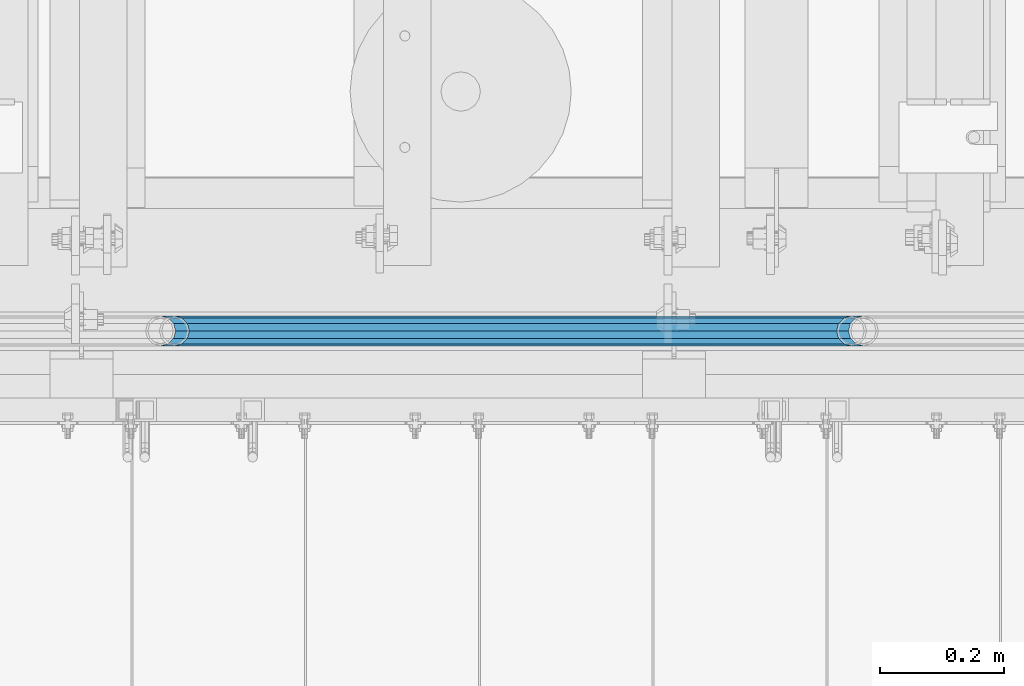
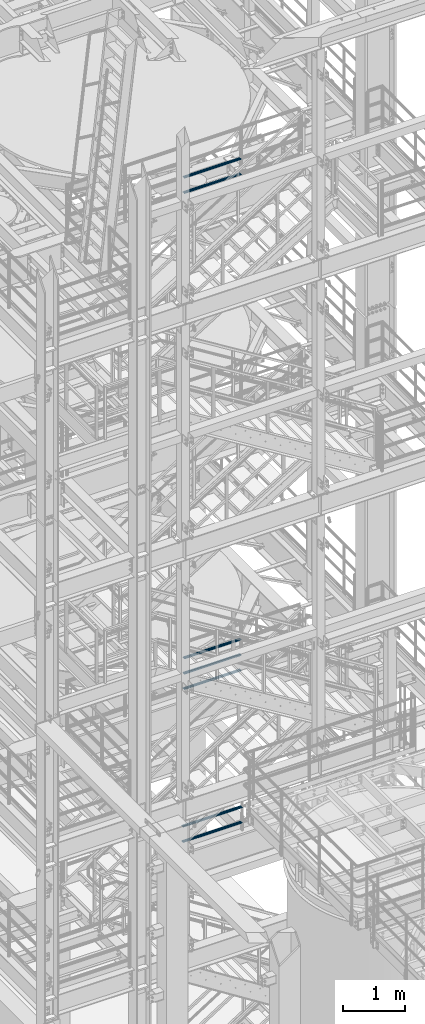
# One storey, part 977 of 1876: 7 beams, 3 elements without a shape of their own.
"""IFC2X3 building model written with IfcOpenShell, lengths in millimetres."""

from ifc_helpers import new_model, si_unit, frame, origin_with_axes, place, context, subcontext, project, spatial, faceted_brep, material, type_object, element, aggregate, save


model = new_model("IFC2X3")

# Units and contexts
model_context = context("Model", 3, precision=1e-05, world=origin_with_axes())
body_context = subcontext(model_context, "Body", "Model", "MODEL_VIEW")
ifc_project = project(units=[si_unit("LENGTHUNIT", "METRE", prefix="MILLI"), si_unit("AREAUNIT", "SQUARE_METRE"), si_unit("VOLUMEUNIT", "CUBIC_METRE"), si_unit("MASSUNIT", "GRAM", prefix="KILO"), si_unit("TIMEUNIT", "SECOND"), si_unit("PLANEANGLEUNIT", "RADIAN"), si_unit("SOLIDANGLEUNIT", "STERADIAN"), si_unit("THERMODYNAMICTEMPERATUREUNIT", "DEGREE_CELSIUS"), si_unit("LUMINOUSINTENSITYUNIT", "LUMEN")], contexts=[model_context])

# Site, building, storey
site_placement = place(None, origin_with_axes())
site = spatial("IfcSite", under=ifc_project, at=site_placement, CompositionType="ELEMENT")
building_placement = place(site_placement, origin_with_axes())
building = spatial("IfcBuilding", under=site, at=building_placement, Name="Undefined", CompositionType="ELEMENT")
storey_placement = place(building_placement, origin_with_axes())
storey = spatial("IfcBuildingStorey", under=building, at=storey_placement, Name="Undefined", CompositionType="ELEMENT", Elevation=0.0)

# Assembly, beams
assembly_1_placement = place(storey_placement, origin_with_axes())
assembly_1 = element("IfcElementAssembly", 1, at=assembly_1_placement, inside=storey, Name="RAIL", AssemblyPlace="NOTDEFINED", PredefinedType="RIGID_FRAME")
ifc_material = material()
beam_type = type_object("IfcBeamType", Name="PIPE1-1/2SCH40", PredefinedType="NOTDEFINED")
beam_1_placement = place(assembly_1_placement, frame((3937.00000015569, -4654.55000114549, 5292.725), z_axis=(0.0, 0.0, 1.0), x_axis=(1.0, 0.0, 0.0)))
beam_1 = element("IfcBeam", 2, at=beam_1_placement, type_object=beam_type, material=ifc_material, Name="RAIL", ObjectType="PIPE1-1/2SCH40", context=body_context, shape_type="Brep", body=[
    faceted_brep([(1109.40280692884, -12.0649999999996, 20.8971929933186), (1109.40280692884, -12.0650000000269, 15.8661214311533), (1108.90937849097, -10.2235000000001, 17.7076214311801), (1106.16999992216, -9.09494701772928e-13, 20.4470000000001), (1106.16999992216, -9.09494701772928e-13, 24.1300000000001), (1108.90937849099, 10.2235000000001, 17.7076214311801), (1109.40280692884, 12.0649999999723, 15.8661214312078), (1109.40280692884, 12.0649999999996, 20.8971929933186), (1130.29999992215, 24.1300000000001, 0.0), (1118.23499992216, 20.8971929933186, 12.0649999999996), (1118.23499992216, 20.8971929933186, -12.0649999999996), (1115.04542836005, 17.7076214311801, 10.2235000000001), (1117.78480692887, 20.4470000000001, 0.0), (1115.04542836005, 17.7076214311801, -10.2235000000001), (1109.40280692884, 12.0649999999723, -15.8661214312078), (1109.40280692884, 12.0649999999996, -20.8971929933186), (1108.90937849099, 10.2235000000001, -17.7076214311801), (1106.16999992216, 0.0, -20.4470000000001), (1106.16999992216, 0.0, -24.1300000000001), (1109.40280692884, -12.0650000000269, -15.8661214311533), (1109.40280692884, -12.0649999999996, -20.8971929933186), (1108.90937849097, -10.2235000000001, -17.7076214311801), (1130.29999992216, -24.1300000000274, 0.0), (1118.23499992216, -20.8971929933186, -12.0649999999996), (1118.23499992216, -20.8971929933186, 12.0649999999996), (1115.04542835999, -17.7076214311801, -10.2235000000001), (1117.78480692881, -20.4470000000001, 0.0), (1115.04542835999, -17.7076214311801, 10.2235000000001), (12.0650000000064, -20.8971929933177, -12.0649999999987), (20.8971929933249, -12.0650000000005, -20.8971929933177), (0.0, 24.1299999999992, 0.0), (12.0650000000064, 20.8971929933177, -12.0649999999987), (12.0650000000064, 20.8971929933177, 12.0649999999987), (20.8971929933249, 12.0650000000005, 20.8971929933177), (24.1300000000064, 0.0, 24.130000000001), (20.8971929933249, 12.0650000000005, -20.8971929933177), (24.1300000000063, 0.0, -24.130000000001), (24.1300000000063, 0.0, -20.4470000000001), (20.8971929933249, -12.0650000000005, -15.8661214311796), (21.3906214311868, -10.2235000000001, -17.7076214311819), (21.3906214311868, 10.2235000000001, -17.7076214311819), (20.8971929933249, 12.0650000000005, -15.8661214311796), (15.2545715621445, 17.7076214311801, -10.2235000000001), (12.5151929933249, 20.4470000000001, 0.0), (15.2545715621445, 17.7076214311801, 10.2235000000001), (20.8971929933249, 12.0650000000005, 15.8661214311796), (21.3906214311868, 10.2235000000001, 17.7076214311819), (24.1300000000064, 0.0, 20.4470000000001), (21.3906214311868, -10.2235000000001, 17.7076214311819), (20.8971929933249, -12.0650000000005, 15.8661214311796), (20.8971929933249, -12.0650000000005, 20.8971929933177), (12.0650000000064, -20.8971929933177, 12.0649999999987), (0.0, -24.1299999999992, 0.0), (15.2545715621445, -17.7076214311801, 10.2235000000001), (12.5151929933249, -20.4470000000001, 0.0), (15.2545715621445, -17.7076214311801, -10.2235000000001)], [[[0, 1, 2, 3, 4]], [[4, 3, 5, 6, 7]], [[8, 9, 10]], [[7, 6, 11, 12, 13, 14, 15, 10, 9]], [[16, 17, 18, 15, 14]], [[19, 20, 18, 17, 21]], [[22, 23, 24]], [[24, 23, 20, 19, 25, 26, 27, 1, 0]], [[28, 29, 20, 23]], [[30, 31, 32]], [[33, 34, 4, 7]], [[32, 33, 7, 9]], [[30, 32, 9, 8]], [[31, 30, 8, 10]], [[35, 31, 10, 15]], [[36, 35, 15, 18]], [[29, 36, 18, 20]], [[37, 36, 29, 38, 39]], [[40, 41, 35, 36, 37]], [[32, 31, 35, 41, 42, 43, 44, 45, 33]], [[33, 45, 46, 47, 34]], [[34, 47, 48, 49, 50]], [[34, 50, 0, 4]], [[50, 51, 24, 0]], [[51, 52, 22, 24]], [[52, 28, 23, 22]], [[51, 28, 52]], [[50, 49, 53, 54, 55, 38, 29, 28, 51]], [[55, 54, 26, 25]], [[21, 39, 38, 55, 25, 19]], [[37, 39, 21, 17]], [[40, 37, 17, 16]], [[42, 41, 40, 16, 14, 13]], [[43, 42, 13, 12]], [[44, 43, 12, 11]], [[5, 46, 45, 44, 11, 6]], [[47, 46, 5, 3]], [[48, 47, 3, 2]], [[53, 49, 48, 2, 1, 27]], [[54, 53, 27, 26]]]),
])
beam_2_placement = place(assembly_1_placement, frame((5067.30000007784, -4654.55000114548, 5597.525), z_axis=(0.0, 0.0, -1.0), x_axis=(-1.0, 0.0, 0.0)))
beam_2 = element("IfcBeam", 3, at=beam_2_placement, type_object=beam_type, material=ifc_material, Name="RAIL", ObjectType="PIPE1-1/2SCH40", context=body_context, shape_type="Brep", body=[
    faceted_brep([(0.0, 24.1299999999992, 0.0), (12.0650000000064, 20.8971929933177, -12.0649999999987), (12.0650000000064, 20.8971929933177, 12.0649999999987), (12.0650000000064, -20.8971929933177, 12.0649999999987), (12.0650000000064, -20.8971929933177, -12.0649999999987), (0.0, -24.1299999999992, 0.0), (20.8971929933249, -12.0650000000005, 20.8971929933177), (20.8971929933249, -12.0650000000005, 15.8661214311796), (15.2545715621445, -17.7076214311801, 10.2235000000001), (12.5151929933249, -20.4470000000001, 0.0), (15.2545715621445, -17.7076214311801, -10.2235000000001), (20.8971929933249, -12.0650000000005, -15.8661214311796), (20.8971929933249, -12.0650000000005, -20.8971929933177), (24.1300000000063, 0.0, -20.4470000000001), (24.1300000000063, 0.0, -24.130000000001), (21.3906214311868, -10.2235000000001, -17.7076214311819), (21.3906214311868, 10.2235000000001, -17.7076214311819), (20.8971929933249, 12.0650000000005, -15.8661214311796), (20.8971929933249, 12.0650000000005, -20.8971929933177), (15.2545715621445, 17.7076214311801, -10.2235000000001), (12.5151929933249, 20.4470000000001, 0.0), (15.2545715621445, 17.7076214311801, 10.2235000000001), (20.8971929933249, 12.0650000000005, 15.8661214311796), (20.8971929933249, 12.0650000000005, 20.8971929933177), (21.3906214311868, 10.2235000000001, 17.7076214311819), (24.1300000000064, 0.0, 20.4470000000001), (24.1300000000064, 0.0, 24.130000000001), (21.3906214311868, -10.2235000000001, 17.7076214311819), (1130.29999992215, 24.1300000000001, 0.0), (1118.23499992216, 20.8971929933186, -12.0649999999996), (1109.40280692884, 12.0649999999996, -20.8971929933186), (1130.29999992216, -24.1300000000274, 0.0), (1118.23499992216, -20.8971929933186, -12.0649999999996), (1118.23499992216, -20.8971929933186, 12.0649999999996), (1109.40280692884, -12.0649999999996, 20.8971929933186), (1109.40280692884, -12.0649999999996, -20.8971929933186), (1106.16999992216, 0.0, -24.1300000000001), (1108.90937849099, 10.2235000000001, -17.7076214311801), (1106.16999992216, 0.0, -20.4470000000001), (1109.40280692884, 12.0649999999723, -15.8661214312078), (1109.40280692884, -12.0650000000269, -15.8661214311533), (1108.90937849097, -10.2235000000001, -17.7076214311801), (1115.04542835999, -17.7076214311801, -10.2235000000001), (1117.78480692881, -20.4470000000001, 0.0), (1115.04542835999, -17.7076214311801, 10.2235000000001), (1109.40280692884, -12.0650000000269, 15.8661214311533), (1108.90937849097, -10.2235000000001, 17.7076214311801), (1106.16999992216, -9.09494701772928e-13, 20.4470000000001), (1106.16999992216, -9.09494701772928e-13, 24.1300000000001), (1109.40280692884, 12.0649999999996, 20.8971929933186), (1118.23499992216, 20.8971929933186, 12.0649999999996), (1109.40280692884, 12.0649999999723, 15.8661214312078), (1115.04542836005, 17.7076214311801, 10.2235000000001), (1117.78480692887, 20.4470000000001, 0.0), (1115.04542836005, 17.7076214311801, -10.2235000000001), (1108.90937849099, 10.2235000000001, 17.7076214311801)], [[[0, 1, 2]], [[3, 4, 5]], [[6, 7, 8, 9, 10, 11, 12, 4, 3]], [[13, 14, 12, 11, 15]], [[16, 17, 18, 14, 13]], [[2, 1, 18, 17, 19, 20, 21, 22, 23]], [[23, 22, 24, 25, 26]], [[26, 25, 27, 7, 6]], [[1, 0, 28, 29]], [[18, 1, 29, 30]], [[31, 32, 33]], [[6, 3, 33, 34]], [[3, 5, 31, 33]], [[5, 4, 32, 31]], [[4, 12, 35, 32]], [[12, 14, 36, 35]], [[14, 18, 30, 36]], [[37, 38, 36, 30, 39]], [[40, 35, 36, 38, 41]], [[33, 32, 35, 40, 42, 43, 44, 45, 34]], [[34, 45, 46, 47, 48]], [[26, 6, 34, 48]], [[2, 23, 49, 50]], [[23, 26, 48, 49]], [[0, 2, 50, 28]], [[28, 50, 29]], [[49, 51, 52, 53, 54, 39, 30, 29, 50]], [[48, 47, 55, 51, 49]], [[25, 24, 55, 47]], [[55, 24, 22, 21, 52, 51]], [[21, 20, 53, 52]], [[20, 19, 54, 53]], [[19, 17, 16, 37, 39, 54]], [[16, 13, 38, 37]], [[13, 15, 41, 38]], [[41, 15, 11, 10, 42, 40]], [[10, 9, 43, 42]], [[9, 8, 44, 43]], [[8, 7, 27, 46, 45, 44]], [[27, 25, 47, 46]]]),
])
aggregate(assembly_1, [beam_1, beam_2])

assembly_2_placement = place(storey_placement, origin_with_axes())
assembly_2 = element("IfcElementAssembly", 4, at=assembly_2_placement, inside=storey, Name="RAIL", AssemblyPlace="NOTDEFINED", PredefinedType="RIGID_FRAME")
beam_3_placement = place(assembly_2_placement, frame((5048.24999996467, -4654.55000114553, 18145.125), z_axis=(0.0, 0.0, 1.0), x_axis=(-1.0, 0.0, 0.0)))
beam_3 = element("IfcBeam", 5, at=beam_3_placement, type_object=beam_type, material=ifc_material, Name="RAIL", ObjectType="PIPE1-1/2SCH40", context=body_context, shape_type="Brep", body=[
    faceted_brep([(1068.12780699489, -12.0649999999996, 20.8971929933177), (1068.12780699489, -12.064999999986, 15.8661214311942), (1067.63437855703, -10.2235000000001, 17.7076214311801), (1064.89499998821, 0.0, 20.4470000000001), (1064.89499998821, 0.0, 24.1299999999992), (1067.63437855703, 10.2235000000001, 17.7076214311801), (1068.12780699489, 12.0650000000132, 15.8661214311669), (1068.12780699489, 12.0649999999996, 20.8971929933177), (1089.02499998822, 24.1300000000001, 0.0), (1076.95999998821, 20.8971929933186, 12.0650000000005), (1076.95999998821, 20.8971929933186, -12.0650000000005), (1073.77042842606, 17.7076214311801, 10.2235000000001), (1076.50980699488, 20.4470000000001, 0.0), (1073.77042842606, 17.7076214311801, -10.2235000000001), (1068.12780699489, 12.0650000000132, -15.8661214311669), (1068.12780699489, 12.0649999999996, -20.8971929933177), (1067.63437855703, 10.2235000000001, -17.7076214311801), (1064.89499998821, 0.0, -20.4470000000001), (1064.89499998821, 0.0, -24.1299999999992), (1068.12780699489, -12.064999999986, -15.8661214311942), (1068.12780699489, -12.0649999999996, -20.8971929933177), (1067.63437855703, -10.2235000000001, -17.7076214311801), (1089.02499998821, -24.1299999999865, 0.0), (1076.95999998821, -20.8971929933186, -12.0650000000005), (1076.95999998821, -20.8971929933186, 12.0650000000005), (1073.77042842609, -17.7076214311801, -10.2235000000001), (1076.50980699491, -20.4470000000001, 0.0), (1073.77042842609, -17.7076214311801, 10.2235000000001), (12.0650000000064, -20.8971929933177, -12.0649999999987), (20.8971929933249, -12.0650000000005, -20.8971929933177), (0.0, 24.1299999999992, 0.0), (12.0650000000064, 20.8971929933177, -12.0649999999987), (12.0650000000064, 20.8971929933177, 12.0649999999987), (20.8971929933249, 12.0650000000005, 20.8971929933177), (24.1300000000064, 0.0, 24.130000000001), (20.8971929933249, 12.0650000000005, -20.8971929933177), (24.1300000000063, 0.0, -24.130000000001), (24.1300000000063, 0.0, -20.4470000000001), (20.8971929933249, -12.0650000000005, -15.8661214311796), (21.3906214311868, -10.2235000000001, -17.7076214311819), (21.3906214311868, 10.2235000000001, -17.7076214311819), (20.8971929933249, 12.0650000000005, -15.8661214311796), (15.2545715621445, 17.7076214311801, -10.2235000000001), (12.5151929933249, 20.4470000000001, 0.0), (15.2545715621445, 17.7076214311801, 10.2235000000001), (20.8971929933249, 12.0650000000005, 15.8661214311796), (21.3906214311868, 10.2235000000001, 17.7076214311819), (24.1300000000064, 0.0, 20.4470000000001), (21.3906214311868, -10.2235000000001, 17.7076214311819), (20.8971929933249, -12.0650000000005, 15.8661214311796), (20.8971929933249, -12.0650000000005, 20.8971929933177), (12.0650000000064, -20.8971929933177, 12.0649999999987), (0.0, -24.1299999999992, 0.0), (15.2545715621445, -17.7076214311801, 10.2235000000001), (12.5151929933249, -20.4470000000001, 0.0), (15.2545715621445, -17.7076214311801, -10.2235000000001)], [[[0, 1, 2, 3, 4]], [[4, 3, 5, 6, 7]], [[8, 9, 10]], [[7, 6, 11, 12, 13, 14, 15, 10, 9]], [[16, 17, 18, 15, 14]], [[19, 20, 18, 17, 21]], [[22, 23, 24]], [[24, 23, 20, 19, 25, 26, 27, 1, 0]], [[28, 29, 20, 23]], [[30, 31, 32]], [[33, 34, 4, 7]], [[32, 33, 7, 9]], [[30, 32, 9, 8]], [[31, 30, 8, 10]], [[35, 31, 10, 15]], [[36, 35, 15, 18]], [[29, 36, 18, 20]], [[37, 36, 29, 38, 39]], [[40, 41, 35, 36, 37]], [[32, 31, 35, 41, 42, 43, 44, 45, 33]], [[33, 45, 46, 47, 34]], [[34, 47, 48, 49, 50]], [[34, 50, 0, 4]], [[50, 51, 24, 0]], [[51, 52, 22, 24]], [[52, 28, 23, 22]], [[51, 28, 52]], [[50, 49, 53, 54, 55, 38, 29, 28, 51]], [[55, 54, 26, 25]], [[21, 39, 38, 55, 25, 19]], [[37, 39, 21, 17]], [[40, 37, 17, 16]], [[42, 41, 40, 16, 14, 13]], [[43, 42, 13, 12]], [[44, 43, 12, 11]], [[5, 46, 45, 44, 11, 6]], [[47, 46, 5, 3]], [[48, 47, 3, 2]], [[53, 49, 48, 2, 1, 27]], [[54, 53, 27, 26]]]),
])
beam_4_placement = place(assembly_2_placement, frame((3959.22499997644, -4654.55000114554, 18449.925), z_axis=(0.0, 0.0, -1.0), x_axis=(1.0, 0.0, 0.0)))
beam_4 = element("IfcBeam", 6, at=beam_4_placement, type_object=beam_type, material=ifc_material, Name="RAIL", ObjectType="PIPE1-1/2SCH40", context=body_context, shape_type="Brep", body=[
    faceted_brep([(0.0, 24.1299999999992, 0.0), (12.0650000000064, 20.8971929933177, -12.0649999999987), (12.0650000000064, 20.8971929933177, 12.0649999999987), (12.0650000000064, -20.8971929933177, 12.0649999999987), (12.0650000000064, -20.8971929933177, -12.0649999999987), (0.0, -24.1299999999992, 0.0), (20.8971929933249, -12.0650000000005, 20.8971929933177), (20.8971929933249, -12.0650000000005, 15.8661214311796), (15.2545715621445, -17.7076214311801, 10.2235000000001), (12.5151929933249, -20.4470000000001, 0.0), (15.2545715621445, -17.7076214311801, -10.2235000000001), (20.8971929933249, -12.0650000000005, -15.8661214311796), (20.8971929933249, -12.0650000000005, -20.8971929933177), (24.1300000000063, 0.0, -20.4470000000001), (24.1300000000063, 0.0, -24.130000000001), (21.3906214311868, -10.2235000000001, -17.7076214311819), (21.3906214311868, 10.2235000000001, -17.7076214311819), (20.8971929933249, 12.0650000000005, -15.8661214311796), (20.8971929933249, 12.0650000000005, -20.8971929933177), (15.2545715621445, 17.7076214311801, -10.2235000000001), (12.5151929933249, 20.4470000000001, 0.0), (15.2545715621445, 17.7076214311801, 10.2235000000001), (20.8971929933249, 12.0650000000005, 15.8661214311796), (20.8971929933249, 12.0650000000005, 20.8971929933177), (21.3906214311868, 10.2235000000001, 17.7076214311819), (24.1300000000064, 0.0, 20.4470000000001), (24.1300000000064, 0.0, 24.130000000001), (21.3906214311868, -10.2235000000001, 17.7076214311819), (1089.02499998822, 24.1300000000001, 0.0), (1076.95999998821, 20.8971929933186, -12.0650000000005), (1068.12780699489, 12.0649999999996, -20.8971929933177), (1089.02499998821, -24.1299999999865, 0.0), (1076.95999998821, -20.8971929933186, -12.0650000000005), (1076.95999998821, -20.8971929933186, 12.0650000000005), (1068.12780699489, -12.0649999999996, 20.8971929933177), (1068.12780699489, -12.0649999999996, -20.8971929933177), (1064.89499998821, 0.0, -24.1299999999992), (1067.63437855703, 10.2235000000001, -17.7076214311801), (1064.89499998821, 0.0, -20.4470000000001), (1068.12780699489, 12.0650000000132, -15.8661214311669), (1068.12780699489, -12.064999999986, -15.8661214311942), (1067.63437855703, -10.2235000000001, -17.7076214311801), (1073.77042842609, -17.7076214311801, -10.2235000000001), (1076.50980699491, -20.4470000000001, 0.0), (1073.77042842609, -17.7076214311801, 10.2235000000001), (1068.12780699489, -12.064999999986, 15.8661214311942), (1067.63437855703, -10.2235000000001, 17.7076214311801), (1064.89499998821, 0.0, 20.4470000000001), (1064.89499998821, 0.0, 24.1299999999992), (1068.12780699489, 12.0649999999996, 20.8971929933177), (1076.95999998821, 20.8971929933186, 12.0650000000005), (1068.12780699489, 12.0650000000132, 15.8661214311669), (1073.77042842606, 17.7076214311801, 10.2235000000001), (1076.50980699488, 20.4470000000001, 0.0), (1073.77042842606, 17.7076214311801, -10.2235000000001), (1067.63437855703, 10.2235000000001, 17.7076214311801)], [[[0, 1, 2]], [[3, 4, 5]], [[6, 7, 8, 9, 10, 11, 12, 4, 3]], [[13, 14, 12, 11, 15]], [[16, 17, 18, 14, 13]], [[2, 1, 18, 17, 19, 20, 21, 22, 23]], [[23, 22, 24, 25, 26]], [[26, 25, 27, 7, 6]], [[1, 0, 28, 29]], [[18, 1, 29, 30]], [[31, 32, 33]], [[6, 3, 33, 34]], [[3, 5, 31, 33]], [[5, 4, 32, 31]], [[4, 12, 35, 32]], [[12, 14, 36, 35]], [[14, 18, 30, 36]], [[37, 38, 36, 30, 39]], [[40, 35, 36, 38, 41]], [[33, 32, 35, 40, 42, 43, 44, 45, 34]], [[34, 45, 46, 47, 48]], [[26, 6, 34, 48]], [[2, 23, 49, 50]], [[23, 26, 48, 49]], [[0, 2, 50, 28]], [[28, 50, 29]], [[49, 51, 52, 53, 54, 39, 30, 29, 50]], [[48, 47, 55, 51, 49]], [[25, 24, 55, 47]], [[55, 24, 22, 21, 52, 51]], [[21, 20, 53, 52]], [[20, 19, 54, 53]], [[19, 17, 16, 37, 39, 54]], [[16, 13, 38, 37]], [[13, 15, 41, 38]], [[41, 15, 11, 10, 42, 40]], [[10, 9, 43, 42]], [[9, 8, 44, 43]], [[8, 7, 27, 46, 45, 44]], [[27, 25, 47, 46]]]),
])
aggregate(assembly_2, [beam_3, beam_4])

assembly_3_placement = place(storey_placement, origin_with_axes())
assembly_3 = element("IfcElementAssembly", 7, at=assembly_3_placement, inside=storey, Name="RAIL", AssemblyPlace="NOTDEFINED", PredefinedType="RIGID_FRAME")
beam_5_placement = place(assembly_3_placement, frame((5048.24999996467, -4654.55000114553, 8315.325), z_axis=(0.0, 0.0, 1.0), x_axis=(-1.0, 0.0, 0.0)))
beam_5 = element("IfcBeam", 8, at=beam_5_placement, type_object=beam_type, material=ifc_material, Name="RAIL", ObjectType="PIPE1-1/2SCH40", context=body_context, shape_type="Brep", body=[
    faceted_brep([(1068.12780699489, -12.0649999999996, 20.8971929933177), (1068.12780699489, -12.064999999986, 15.8661214311942), (1067.63437855703, -10.2235000000001, 17.7076214311801), (1064.89499998821, 0.0, 20.4470000000001), (1064.89499998821, 0.0, 24.1299999999992), (1067.63437855703, 10.2235000000001, 17.7076214311801), (1068.12780699489, 12.0650000000132, 15.8661214311669), (1068.12780699489, 12.0649999999996, 20.8971929933177), (1089.02499998822, 24.1300000000001, 0.0), (1076.95999998821, 20.8971929933186, 12.0650000000005), (1076.95999998821, 20.8971929933186, -12.0650000000005), (1073.77042842606, 17.7076214311801, 10.2235000000001), (1076.50980699488, 20.4470000000001, 0.0), (1073.77042842606, 17.7076214311801, -10.2235000000001), (1068.12780699489, 12.0650000000132, -15.8661214311669), (1068.12780699489, 12.0649999999996, -20.8971929933177), (1067.63437855703, 10.2235000000001, -17.7076214311801), (1064.89499998821, 0.0, -20.4470000000001), (1064.89499998821, 0.0, -24.1299999999992), (1068.12780699489, -12.064999999986, -15.8661214311942), (1068.12780699489, -12.0649999999996, -20.8971929933177), (1067.63437855703, -10.2235000000001, -17.7076214311801), (1089.02499998821, -24.1299999999865, 0.0), (1076.95999998821, -20.8971929933186, -12.0650000000005), (1076.95999998821, -20.8971929933186, 12.0650000000005), (1073.77042842609, -17.7076214311801, -10.2235000000001), (1076.50980699491, -20.4470000000001, 0.0), (1073.77042842609, -17.7076214311801, 10.2235000000001), (12.0650000000064, -20.8971929933177, -12.0649999999987), (20.8971929933249, -12.0650000000005, -20.8971929933177), (0.0, 24.1299999999992, 0.0), (12.0650000000064, 20.8971929933177, -12.0649999999987), (12.0650000000064, 20.8971929933177, 12.0649999999987), (20.8971929933249, 12.0650000000005, 20.8971929933177), (24.1300000000064, 0.0, 24.130000000001), (20.8971929933249, 12.0650000000005, -20.8971929933177), (24.1300000000063, 0.0, -24.130000000001), (24.1300000000063, 0.0, -20.4470000000001), (20.8971929933249, -12.0650000000005, -15.8661214311796), (21.3906214311868, -10.2235000000001, -17.7076214311819), (21.3906214311868, 10.2235000000001, -17.7076214311819), (20.8971929933249, 12.0650000000005, -15.8661214311796), (15.2545715621445, 17.7076214311801, -10.2235000000001), (12.5151929933249, 20.4470000000001, 0.0), (15.2545715621445, 17.7076214311801, 10.2235000000001), (20.8971929933249, 12.0650000000005, 15.8661214311796), (21.3906214311868, 10.2235000000001, 17.7076214311819), (24.1300000000064, 0.0, 20.4470000000001), (21.3906214311868, -10.2235000000001, 17.7076214311819), (20.8971929933249, -12.0650000000005, 15.8661214311796), (20.8971929933249, -12.0650000000005, 20.8971929933177), (12.0650000000064, -20.8971929933177, 12.0649999999987), (0.0, -24.1299999999992, 0.0), (15.2545715621445, -17.7076214311801, 10.2235000000001), (12.5151929933249, -20.4470000000001, 0.0), (15.2545715621445, -17.7076214311801, -10.2235000000001)], [[[0, 1, 2, 3, 4]], [[4, 3, 5, 6, 7]], [[8, 9, 10]], [[7, 6, 11, 12, 13, 14, 15, 10, 9]], [[16, 17, 18, 15, 14]], [[19, 20, 18, 17, 21]], [[22, 23, 24]], [[24, 23, 20, 19, 25, 26, 27, 1, 0]], [[28, 29, 20, 23]], [[30, 31, 32]], [[33, 34, 4, 7]], [[32, 33, 7, 9]], [[30, 32, 9, 8]], [[31, 30, 8, 10]], [[35, 31, 10, 15]], [[36, 35, 15, 18]], [[29, 36, 18, 20]], [[37, 36, 29, 38, 39]], [[40, 41, 35, 36, 37]], [[32, 31, 35, 41, 42, 43, 44, 45, 33]], [[33, 45, 46, 47, 34]], [[34, 47, 48, 49, 50]], [[34, 50, 0, 4]], [[50, 51, 24, 0]], [[51, 52, 22, 24]], [[52, 28, 23, 22]], [[51, 28, 52]], [[50, 49, 53, 54, 55, 38, 29, 28, 51]], [[55, 54, 26, 25]], [[21, 39, 38, 55, 25, 19]], [[37, 39, 21, 17]], [[40, 37, 17, 16]], [[42, 41, 40, 16, 14, 13]], [[43, 42, 13, 12]], [[44, 43, 12, 11]], [[5, 46, 45, 44, 11, 6]], [[47, 46, 5, 3]], [[48, 47, 3, 2]], [[53, 49, 48, 2, 1, 27]], [[54, 53, 27, 26]]]),
])
beam_6_placement = place(assembly_3_placement, frame((3959.22499997644, -4654.55000114554, 8620.125), z_axis=(0.0, 0.0, -1.0), x_axis=(1.0, 0.0, 0.0)))
beam_6 = element("IfcBeam", 9, at=beam_6_placement, type_object=beam_type, material=ifc_material, Name="RAIL", ObjectType="PIPE1-1/2SCH40", context=body_context, shape_type="Brep", body=[
    faceted_brep([(0.0, 24.1299999999992, 0.0), (12.0650000000064, 20.8971929933177, -12.0649999999987), (12.0650000000064, 20.8971929933177, 12.0649999999987), (12.0650000000064, -20.8971929933177, 12.0649999999987), (12.0650000000064, -20.8971929933177, -12.0649999999987), (0.0, -24.1299999999992, 0.0), (20.8971929933249, -12.0650000000005, 20.8971929933177), (20.8971929933249, -12.0650000000005, 15.8661214311796), (15.2545715621445, -17.7076214311801, 10.2235000000001), (12.5151929933249, -20.4470000000001, 0.0), (15.2545715621445, -17.7076214311801, -10.2235000000001), (20.8971929933249, -12.0650000000005, -15.8661214311796), (20.8971929933249, -12.0650000000005, -20.8971929933177), (24.1300000000063, 0.0, -20.4470000000001), (24.1300000000063, 0.0, -24.130000000001), (21.3906214311868, -10.2235000000001, -17.7076214311819), (21.3906214311868, 10.2235000000001, -17.7076214311819), (20.8971929933249, 12.0650000000005, -15.8661214311796), (20.8971929933249, 12.0650000000005, -20.8971929933177), (15.2545715621445, 17.7076214311801, -10.2235000000001), (12.5151929933249, 20.4470000000001, 0.0), (15.2545715621445, 17.7076214311801, 10.2235000000001), (20.8971929933249, 12.0650000000005, 15.8661214311796), (20.8971929933249, 12.0650000000005, 20.8971929933177), (21.3906214311868, 10.2235000000001, 17.7076214311819), (24.1300000000064, 0.0, 20.4470000000001), (24.1300000000064, 0.0, 24.130000000001), (21.3906214311868, -10.2235000000001, 17.7076214311819), (1089.02499998822, 24.1300000000001, 0.0), (1076.95999998821, 20.8971929933186, -12.0650000000005), (1068.12780699489, 12.0649999999996, -20.8971929933177), (1089.02499998821, -24.1299999999865, 0.0), (1076.95999998821, -20.8971929933186, -12.0650000000005), (1076.95999998821, -20.8971929933186, 12.0650000000005), (1068.12780699489, -12.0649999999996, 20.8971929933177), (1068.12780699489, -12.0649999999996, -20.8971929933177), (1064.89499998821, 0.0, -24.1299999999992), (1067.63437855703, 10.2235000000001, -17.7076214311801), (1064.89499998821, 0.0, -20.4470000000001), (1068.12780699489, 12.0650000000132, -15.8661214311669), (1068.12780699489, -12.064999999986, -15.8661214311942), (1067.63437855703, -10.2235000000001, -17.7076214311801), (1073.77042842609, -17.7076214311801, -10.2235000000001), (1076.50980699491, -20.4470000000001, 0.0), (1073.77042842609, -17.7076214311801, 10.2235000000001), (1068.12780699489, -12.064999999986, 15.8661214311942), (1067.63437855703, -10.2235000000001, 17.7076214311801), (1064.89499998821, 0.0, 20.4470000000001), (1064.89499998821, 0.0, 24.1299999999992), (1068.12780699489, 12.0649999999996, 20.8971929933177), (1076.95999998821, 20.8971929933186, 12.0650000000005), (1068.12780699489, 12.0650000000132, 15.8661214311669), (1073.77042842606, 17.7076214311801, 10.2235000000001), (1076.50980699488, 20.4470000000001, 0.0), (1073.77042842606, 17.7076214311801, -10.2235000000001), (1067.63437855703, 10.2235000000001, 17.7076214311801)], [[[0, 1, 2]], [[3, 4, 5]], [[6, 7, 8, 9, 10, 11, 12, 4, 3]], [[13, 14, 12, 11, 15]], [[16, 17, 18, 14, 13]], [[2, 1, 18, 17, 19, 20, 21, 22, 23]], [[23, 22, 24, 25, 26]], [[26, 25, 27, 7, 6]], [[1, 0, 28, 29]], [[18, 1, 29, 30]], [[31, 32, 33]], [[6, 3, 33, 34]], [[3, 5, 31, 33]], [[5, 4, 32, 31]], [[4, 12, 35, 32]], [[12, 14, 36, 35]], [[14, 18, 30, 36]], [[37, 38, 36, 30, 39]], [[40, 35, 36, 38, 41]], [[33, 32, 35, 40, 42, 43, 44, 45, 34]], [[34, 45, 46, 47, 48]], [[26, 6, 34, 48]], [[2, 23, 49, 50]], [[23, 26, 48, 49]], [[0, 2, 50, 28]], [[28, 50, 29]], [[49, 51, 52, 53, 54, 39, 30, 29, 50]], [[48, 47, 55, 51, 49]], [[25, 24, 55, 47]], [[55, 24, 22, 21, 52, 51]], [[21, 20, 53, 52]], [[20, 19, 54, 53]], [[19, 17, 16, 37, 39, 54]], [[16, 13, 38, 37]], [[13, 15, 41, 38]], [[41, 15, 11, 10, 42, 40]], [[10, 9, 43, 42]], [[9, 8, 44, 43]], [[8, 7, 27, 46, 45, 44]], [[27, 25, 47, 46]]]),
])
beam_7_placement = place(assembly_3_placement, frame((3959.22499997644, -4654.55000114554, 8924.925), z_axis=(0.0, 0.0, -1.0), x_axis=(1.0, 0.0, 0.0)))
beam_7 = element("IfcBeam", 10, at=beam_7_placement, type_object=beam_type, material=ifc_material, Name="RAIL", ObjectType="PIPE1-1/2SCH40", context=body_context, shape_type="Brep", body=[
    faceted_brep([(0.0, 24.1299999999992, 0.0), (12.0650000000064, 20.8971929933177, -12.0649999999987), (12.0650000000064, 20.8971929933177, 12.0649999999987), (12.0650000000064, -20.8971929933177, 12.0649999999987), (12.0650000000064, -20.8971929933177, -12.0649999999987), (0.0, -24.1299999999992, 0.0), (20.8971929933249, -12.0650000000005, 20.8971929933177), (20.8971929933249, -12.0650000000005, 15.8661214311796), (15.2545715621445, -17.7076214311801, 10.2235000000001), (12.5151929933249, -20.4470000000001, 0.0), (15.2545715621445, -17.7076214311801, -10.2235000000001), (20.8971929933249, -12.0650000000005, -15.8661214311796), (20.8971929933249, -12.0650000000005, -20.8971929933177), (24.1300000000063, 0.0, -20.4470000000001), (24.1300000000063, 0.0, -24.130000000001), (21.3906214311868, -10.2235000000001, -17.7076214311819), (21.3906214311868, 10.2235000000001, -17.7076214311819), (20.8971929933249, 12.0650000000005, -15.8661214311796), (20.8971929933249, 12.0650000000005, -20.8971929933177), (15.2545715621445, 17.7076214311801, -10.2235000000001), (12.5151929933249, 20.4470000000001, 0.0), (15.2545715621445, 17.7076214311801, 10.2235000000001), (20.8971929933249, 12.0650000000005, 15.8661214311796), (20.8971929933249, 12.0650000000005, 20.8971929933177), (21.3906214311868, 10.2235000000001, 17.7076214311819), (24.1300000000064, 0.0, 20.4470000000001), (24.1300000000064, 0.0, 24.130000000001), (21.3906214311868, -10.2235000000001, 17.7076214311819), (1089.02499998822, 24.1300000000001, 0.0), (1076.95999998821, 20.8971929933186, -12.0650000000005), (1068.12780699489, 12.0649999999996, -20.8971929933177), (1089.02499998821, -24.1299999999865, 0.0), (1076.95999998821, -20.8971929933186, -12.0650000000005), (1076.95999998821, -20.8971929933186, 12.0650000000005), (1068.12780699489, -12.0649999999996, 20.8971929933177), (1068.12780699489, -12.0649999999996, -20.8971929933177), (1064.89499998821, 0.0, -24.1299999999992), (1067.63437855703, 10.2235000000001, -17.7076214311801), (1064.89499998821, 0.0, -20.4470000000001), (1068.12780699489, 12.0650000000132, -15.8661214311669), (1068.12780699489, -12.064999999986, -15.8661214311942), (1067.63437855703, -10.2235000000001, -17.7076214311801), (1073.77042842609, -17.7076214311801, -10.2235000000001), (1076.50980699491, -20.4470000000001, 0.0), (1073.77042842609, -17.7076214311801, 10.2235000000001), (1068.12780699489, -12.064999999986, 15.8661214311942), (1067.63437855703, -10.2235000000001, 17.7076214311801), (1064.89499998821, 0.0, 20.4470000000001), (1064.89499998821, 0.0, 24.1299999999992), (1068.12780699489, 12.0649999999996, 20.8971929933177), (1076.95999998821, 20.8971929933186, 12.0650000000005), (1068.12780699489, 12.0650000000132, 15.8661214311669), (1073.77042842606, 17.7076214311801, 10.2235000000001), (1076.50980699488, 20.4470000000001, 0.0), (1073.77042842606, 17.7076214311801, -10.2235000000001), (1067.63437855703, 10.2235000000001, 17.7076214311801)], [[[0, 1, 2]], [[3, 4, 5]], [[6, 7, 8, 9, 10, 11, 12, 4, 3]], [[13, 14, 12, 11, 15]], [[16, 17, 18, 14, 13]], [[2, 1, 18, 17, 19, 20, 21, 22, 23]], [[23, 22, 24, 25, 26]], [[26, 25, 27, 7, 6]], [[1, 0, 28, 29]], [[18, 1, 29, 30]], [[31, 32, 33]], [[6, 3, 33, 34]], [[3, 5, 31, 33]], [[5, 4, 32, 31]], [[4, 12, 35, 32]], [[12, 14, 36, 35]], [[14, 18, 30, 36]], [[37, 38, 36, 30, 39]], [[40, 35, 36, 38, 41]], [[33, 32, 35, 40, 42, 43, 44, 45, 34]], [[34, 45, 46, 47, 48]], [[26, 6, 34, 48]], [[2, 23, 49, 50]], [[23, 26, 48, 49]], [[0, 2, 50, 28]], [[28, 50, 29]], [[49, 51, 52, 53, 54, 39, 30, 29, 50]], [[48, 47, 55, 51, 49]], [[25, 24, 55, 47]], [[55, 24, 22, 21, 52, 51]], [[21, 20, 53, 52]], [[20, 19, 54, 53]], [[19, 17, 16, 37, 39, 54]], [[16, 13, 38, 37]], [[13, 15, 41, 38]], [[41, 15, 11, 10, 42, 40]], [[10, 9, 43, 42]], [[9, 8, 44, 43]], [[8, 7, 27, 46, 45, 44]], [[27, 25, 47, 46]]]),
])
aggregate(assembly_3, [beam_5, beam_6, beam_7])

save(model, "model.ifc")
